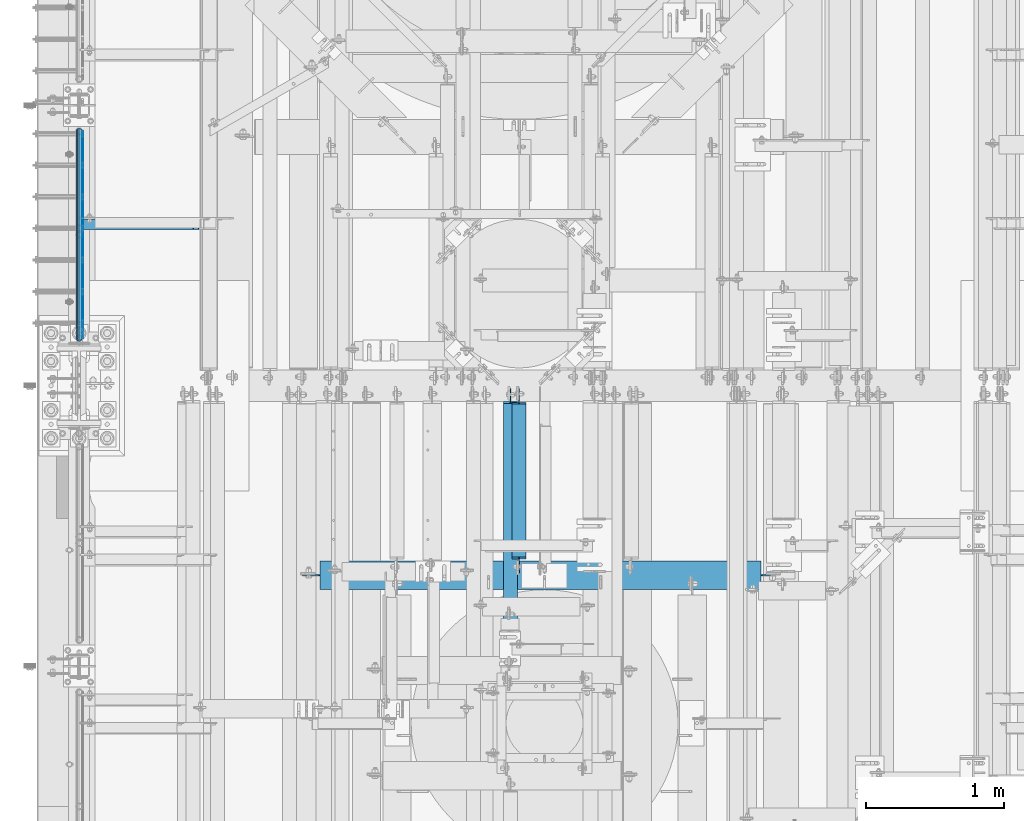
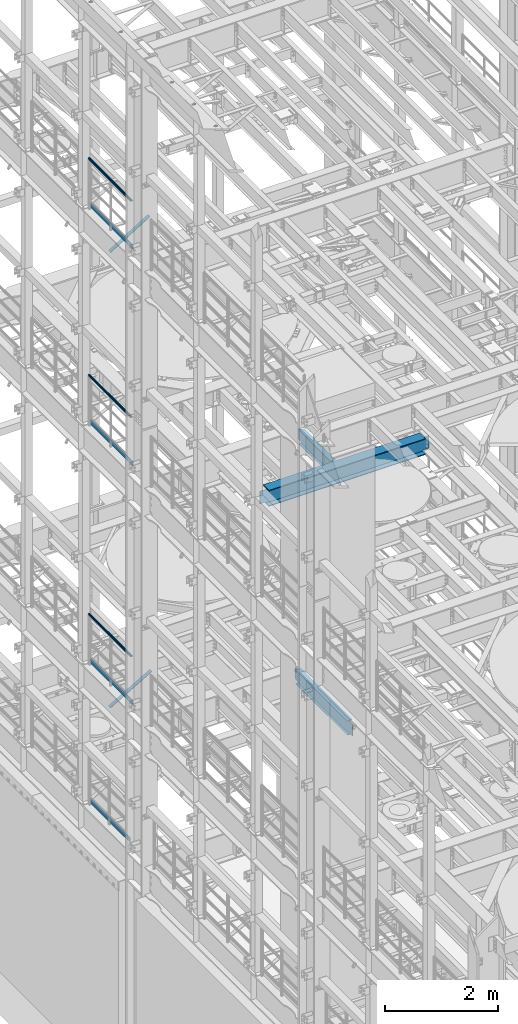
# One storey, part 1042 of 1876: 10 beams, 2 members, 9 elements without a shape of their own.
"""IFC2X3 building model written with IfcOpenShell, lengths in millimetres."""

from ifc_helpers import new_model, si_unit, frame, origin_with_axes, place, context, subcontext, project, spatial, faceted_brep, material, type_object, element, aggregate, save


model = new_model("IFC2X3")

# Units and contexts
model_context = context("Model", 3, precision=1e-05, world=origin_with_axes())
body_context = subcontext(model_context, "Body", "Model", "MODEL_VIEW")
ifc_project = project(units=[si_unit("LENGTHUNIT", "METRE", prefix="MILLI"), si_unit("AREAUNIT", "SQUARE_METRE"), si_unit("VOLUMEUNIT", "CUBIC_METRE"), si_unit("MASSUNIT", "GRAM", prefix="KILO"), si_unit("TIMEUNIT", "SECOND"), si_unit("PLANEANGLEUNIT", "RADIAN"), si_unit("SOLIDANGLEUNIT", "STERADIAN"), si_unit("THERMODYNAMICTEMPERATUREUNIT", "DEGREE_CELSIUS"), si_unit("LUMINOUSINTENSITYUNIT", "LUMEN")], contexts=[model_context])

# Site, building, storey
site_placement = place(None, origin_with_axes())
site = spatial("IfcSite", under=ifc_project, at=site_placement, CompositionType="ELEMENT")
building_placement = place(site_placement, origin_with_axes())
building = spatial("IfcBuilding", under=site, at=building_placement, Name="Undefined", CompositionType="ELEMENT")
storey_placement = place(building_placement, origin_with_axes())
storey = spatial("IfcBuildingStorey", under=building, at=storey_placement, Name="Undefined", CompositionType="ELEMENT", Elevation=0.0)

# Assembly, beam
assembly_1_placement = place(storey_placement, origin_with_axes())
assembly_1 = element("IfcElementAssembly", 1, at=assembly_1_placement, inside=storey, Name="RAIL", AssemblyPlace="NOTDEFINED", PredefinedType="RIGID_FRAME")
ifc_material_1 = material()
beam_type_1 = type_object("IfcBeamType", Name="PIPE1-1/2SCH40", PredefinedType="NOTDEFINED")
beam_1_placement = place(assembly_1_placement, frame((-1.81898940354586e-12, 7940.675, 19059.525), z_axis=(0.0, 0.0, -1.0), x_axis=(0.0, 1.0, 0.0)))
beam_1 = element("IfcBeam", 2, at=beam_1_placement, type_object=beam_type_1, material=ifc_material_1, Name="RAIL", ObjectType="PIPE1-1/2SCH40", context=body_context, shape_type="Brep", body=[
    faceted_brep([(24.1300000000001, -20.4469999999999, 0.0), (34.3535000000002, -17.7076214311803, 10.2235000000001), (1511.8715, -17.7076214311801, 10.2235000000001), (1522.095, -20.4470000000001, 0.0), (41.8376214311802, -10.2235000000001, 17.7076214311819), (1504.38737856882, -10.2235000000001, 17.7076214311819), (44.5770000000002, 0.0, 20.4470000000001), (1501.648, 0.0, 20.4470000000001), (41.8376214311802, 10.2235000000001, 17.7076214311819), (1504.38737856882, 10.2235000000001, 17.7076214311819), (34.3535000000002, 17.7076214311803, 10.2235000000001), (1511.8715, 17.7076214311801, 10.2235000000001), (24.1300000000001, 20.4469999999999, 0.0), (1522.095, 20.4470000000001, 0.0), (13.9065000000001, 17.7076214311803, -10.2235000000001), (1532.3185, 17.7076214311801, -10.2235000000001), (6.42237856882002, 10.2235000000001, -17.7076214311819), (1539.80262143118, 10.2235000000001, -17.7076214311819), (3.68299999999999, 0.0, -20.4470000000001), (1542.542, 0.0, -20.4470000000001), (6.42237856882002, -10.2235000000001, -17.7076214311819), (1539.80262143118, -10.2235000000001, -17.7076214311819), (13.9065000000001, -17.7076214311803, -10.2235000000001), (1532.3185, -17.7076214311801, -10.2235000000001), (24.1299999999854, -24.1299999999992, 0.0), (12.0650000000064, -20.8971929933177, -12.0649999999987), (1534.16, -20.8971929933186, -12.0649999999987), (1522.095, -24.1300000000001, 0.0), (3.23280700668147, -12.0650000000001, -20.8971929933177), (1542.99219299332, -12.0649999999996, -20.8971929933177), (-1.45519152283669e-11, 0.0, -24.130000000001), (1546.225, 0.0, -24.130000000001), (3.23280700668147, 12.0650000000001, -20.8971929933177), (1542.99219299332, 12.0649999999996, -20.8971929933177), (12.0650000000064, 20.8971929933177, -12.0649999999987), (1534.16, 20.8971929933186, -12.0649999999987), (24.1300000000047, 24.1299999999992, 0.0), (1522.095, 24.1300000000001, 0.0), (36.1949999999997, 20.8971929933184, 12.0649999999987), (1510.03, 20.8971929933186, 12.0649999999987), (45.0271929933187, 12.0650000000001, 20.8971929933177), (1501.19780700668, 12.0649999999996, 20.8971929933177), (48.2600000000002, 0.0, 24.130000000001), (1497.965, 0.0, 24.130000000001), (45.0271929933187, -12.0650000000001, 20.8971929933177), (1501.19780700668, -12.0649999999996, 20.8971929933177), (36.1949999999997, -20.8971929933184, 12.0649999999987), (1510.03, -20.8971929933186, 12.0649999999987)], [[[0, 1, 2, 3]], [[1, 4, 5, 2]], [[4, 6, 7, 5]], [[6, 8, 9, 7]], [[8, 10, 11, 9]], [[10, 12, 13, 11]], [[12, 14, 15, 13]], [[14, 16, 17, 15]], [[16, 18, 19, 17]], [[18, 20, 21, 19]], [[20, 22, 23, 21]], [[22, 0, 3, 23]], [[24, 25, 26, 27]], [[25, 28, 29, 26]], [[28, 30, 31, 29]], [[30, 32, 33, 31]], [[32, 34, 35, 33]], [[34, 36, 37, 35]], [[36, 38, 39, 37]], [[38, 40, 41, 39]], [[40, 42, 43, 41]], [[42, 44, 45, 43]], [[44, 46, 47, 45]], [[46, 24, 27, 47]], [[29, 31, 33, 35, 37, 39, 41, 43, 45, 47, 27, 26], [5, 7, 9, 11, 13, 15, 17, 19, 21, 23, 3, 2]], [[46, 44, 42, 40, 38, 36, 34, 32, 30, 28, 25, 24], [22, 20, 18, 16, 14, 12, 10, 8, 6, 4, 1, 0]]]),
])

assembly_2_placement = place(storey_placement, origin_with_axes())
assembly_2 = element("IfcElementAssembly", 3, at=assembly_2_placement, inside=storey, Name="RAIL", AssemblyPlace="NOTDEFINED", PredefinedType="RIGID_FRAME")
beam_2_placement = place(assembly_2_placement, frame((-1.81898940354586e-12, 7940.675, 14385.925), z_axis=(0.0, 0.0, -1.0), x_axis=(0.0, 1.0, 0.0)))
beam_2 = element("IfcBeam", 4, at=beam_2_placement, type_object=beam_type_1, material=ifc_material_1, Name="RAIL", ObjectType="PIPE1-1/2SCH40", context=body_context, shape_type="Brep", body=[
    faceted_brep([(24.1300000000001, -20.4469999999999, 0.0), (34.3535000000002, -17.7076214311803, 10.2235000000001), (1511.8715, -17.7076214311801, 10.2235000000001), (1522.095, -20.4470000000001, 0.0), (41.8376214311802, -10.2235000000001, 17.7076214311819), (1504.38737856882, -10.2235000000001, 17.7076214311819), (44.5770000000002, 0.0, 20.4470000000001), (1501.648, 0.0, 20.4470000000001), (41.8376214311802, 10.2235000000001, 17.7076214311819), (1504.38737856882, 10.2235000000001, 17.7076214311819), (34.3535000000002, 17.7076214311803, 10.2235000000001), (1511.8715, 17.7076214311801, 10.2235000000001), (24.1300000000001, 20.4469999999999, 0.0), (1522.095, 20.4470000000001, 0.0), (13.9065000000001, 17.7076214311803, -10.2235000000001), (1532.3185, 17.7076214311801, -10.2235000000001), (6.42237856882002, 10.2235000000001, -17.7076214311819), (1539.80262143118, 10.2235000000001, -17.7076214311819), (3.68299999999999, 0.0, -20.4470000000001), (1542.542, 0.0, -20.4470000000001), (6.42237856882002, -10.2235000000001, -17.7076214311819), (1539.80262143118, -10.2235000000001, -17.7076214311819), (13.9065000000001, -17.7076214311803, -10.2235000000001), (1532.3185, -17.7076214311801, -10.2235000000001), (24.1299999999854, -24.1299999999992, 0.0), (12.0650000000064, -20.8971929933177, -12.0649999999987), (1534.16, -20.8971929933186, -12.0649999999987), (1522.095, -24.1300000000001, 0.0), (3.23280700668147, -12.0650000000001, -20.8971929933177), (1542.99219299332, -12.0649999999996, -20.8971929933177), (-1.45519152283669e-11, 0.0, -24.130000000001), (1546.225, 0.0, -24.130000000001), (3.23280700668147, 12.0650000000001, -20.8971929933177), (1542.99219299332, 12.0649999999996, -20.8971929933177), (12.0650000000064, 20.8971929933177, -12.0649999999987), (1534.16, 20.8971929933186, -12.0649999999987), (24.1300000000047, 24.1299999999992, 0.0), (1522.095, 24.1300000000001, 0.0), (36.1949999999997, 20.8971929933184, 12.0649999999987), (1510.03, 20.8971929933186, 12.0649999999987), (45.0271929933187, 12.0650000000001, 20.8971929933177), (1501.19780700668, 12.0649999999996, 20.8971929933177), (48.2600000000002, 0.0, 24.130000000001), (1497.965, 0.0, 24.130000000001), (45.0271929933187, -12.0650000000001, 20.8971929933177), (1501.19780700668, -12.0649999999996, 20.8971929933177), (36.1949999999997, -20.8971929933184, 12.0649999999987), (1510.03, -20.8971929933186, 12.0649999999987)], [[[0, 1, 2, 3]], [[1, 4, 5, 2]], [[4, 6, 7, 5]], [[6, 8, 9, 7]], [[8, 10, 11, 9]], [[10, 12, 13, 11]], [[12, 14, 15, 13]], [[14, 16, 17, 15]], [[16, 18, 19, 17]], [[18, 20, 21, 19]], [[20, 22, 23, 21]], [[22, 0, 3, 23]], [[24, 25, 26, 27]], [[25, 28, 29, 26]], [[28, 30, 31, 29]], [[30, 32, 33, 31]], [[32, 34, 35, 33]], [[34, 36, 37, 35]], [[36, 38, 39, 37]], [[38, 40, 41, 39]], [[40, 42, 43, 41]], [[42, 44, 45, 43]], [[44, 46, 47, 45]], [[46, 24, 27, 47]], [[29, 31, 33, 35, 37, 39, 41, 43, 45, 47, 27, 26], [5, 7, 9, 11, 13, 15, 17, 19, 21, 23, 3, 2]], [[46, 44, 42, 40, 38, 36, 34, 32, 30, 28, 25, 24], [22, 20, 18, 16, 14, 12, 10, 8, 6, 4, 1, 0]]]),
])

assembly_3_placement = place(storey_placement, origin_with_axes())
assembly_3 = element("IfcElementAssembly", 5, at=assembly_3_placement, inside=storey, Name="RAIL", AssemblyPlace="NOTDEFINED", PredefinedType="RIGID_FRAME")
beam_3_placement = place(assembly_3_placement, frame((-1.81898940354586e-12, 7940.675, 9229.725), z_axis=(0.0, 0.0, -1.0), x_axis=(0.0, 1.0, 0.0)))
beam_3 = element("IfcBeam", 6, at=beam_3_placement, type_object=beam_type_1, material=ifc_material_1, Name="RAIL", ObjectType="PIPE1-1/2SCH40", context=body_context, shape_type="Brep", body=[
    faceted_brep([(24.1300000000001, -20.4469999999999, 0.0), (34.3535000000002, -17.7076214311803, 10.2235000000001), (1511.8715, -17.7076214311801, 10.2235000000001), (1522.095, -20.4470000000001, 0.0), (41.8376214311802, -10.2235000000001, 17.7076214311819), (1504.38737856882, -10.2235000000001, 17.7076214311819), (44.5770000000002, 0.0, 20.4470000000001), (1501.648, 0.0, 20.4470000000001), (41.8376214311802, 10.2235000000001, 17.7076214311819), (1504.38737856882, 10.2235000000001, 17.7076214311819), (34.3535000000002, 17.7076214311803, 10.2235000000001), (1511.8715, 17.7076214311801, 10.2235000000001), (24.1300000000001, 20.4469999999999, 0.0), (1522.095, 20.4470000000001, 0.0), (13.9065000000001, 17.7076214311803, -10.2235000000001), (1532.3185, 17.7076214311801, -10.2235000000001), (6.42237856882002, 10.2235000000001, -17.7076214311819), (1539.80262143118, 10.2235000000001, -17.7076214311819), (3.68299999999999, 0.0, -20.4470000000001), (1542.542, 0.0, -20.4470000000001), (6.42237856882002, -10.2235000000001, -17.7076214311819), (1539.80262143118, -10.2235000000001, -17.7076214311819), (13.9065000000001, -17.7076214311803, -10.2235000000001), (1532.3185, -17.7076214311801, -10.2235000000001), (24.1299999999854, -24.1299999999992, 0.0), (12.0650000000064, -20.8971929933177, -12.0649999999987), (1534.16, -20.8971929933186, -12.0649999999987), (1522.095, -24.1300000000001, 0.0), (3.23280700668147, -12.0650000000001, -20.8971929933177), (1542.99219299332, -12.0649999999996, -20.8971929933177), (-1.45519152283669e-11, 0.0, -24.130000000001), (1546.225, 0.0, -24.130000000001), (3.23280700668147, 12.0650000000001, -20.8971929933177), (1542.99219299332, 12.0649999999996, -20.8971929933177), (12.0650000000064, 20.8971929933177, -12.0649999999987), (1534.16, 20.8971929933186, -12.0649999999987), (24.1300000000047, 24.1299999999992, 0.0), (1522.095, 24.1300000000001, 0.0), (36.1949999999997, 20.8971929933184, 12.0649999999987), (1510.03, 20.8971929933186, 12.0649999999987), (45.0271929933187, 12.0650000000001, 20.8971929933177), (1501.19780700668, 12.0649999999996, 20.8971929933177), (48.2600000000002, 0.0, 24.130000000001), (1497.965, 0.0, 24.130000000001), (45.0271929933187, -12.0650000000001, 20.8971929933177), (1501.19780700668, -12.0649999999996, 20.8971929933177), (36.1949999999997, -20.8971929933184, 12.0649999999987), (1510.03, -20.8971929933186, 12.0649999999987)], [[[0, 1, 2, 3]], [[1, 4, 5, 2]], [[4, 6, 7, 5]], [[6, 8, 9, 7]], [[8, 10, 11, 9]], [[10, 12, 13, 11]], [[12, 14, 15, 13]], [[14, 16, 17, 15]], [[16, 18, 19, 17]], [[18, 20, 21, 19]], [[20, 22, 23, 21]], [[22, 0, 3, 23]], [[24, 25, 26, 27]], [[25, 28, 29, 26]], [[28, 30, 31, 29]], [[30, 32, 33, 31]], [[32, 34, 35, 33]], [[34, 36, 37, 35]], [[36, 38, 39, 37]], [[38, 40, 41, 39]], [[40, 42, 43, 41]], [[42, 44, 45, 43]], [[44, 46, 47, 45]], [[46, 24, 27, 47]], [[29, 31, 33, 35, 37, 39, 41, 43, 45, 47, 27, 26], [5, 7, 9, 11, 13, 15, 17, 19, 21, 23, 3, 2]], [[46, 44, 42, 40, 38, 36, 34, 32, 30, 28, 25, 24], [22, 20, 18, 16, 14, 12, 10, 8, 6, 4, 1, 0]]]),
])

# Beam
ifc_material_2 = material(Name="STEEL/A36")
beam_type_2 = type_object("IfcBeamType", PredefinedType="NOTDEFINED")
beam_4_placement = place(assembly_1_placement, frame((27.3049999999948, 7964.805, 18049.875), z_axis=(0.0, 0.0, 1.0), x_axis=(0.0, 1.0, 0.0)))
beam_4 = element("IfcBeam", 7, at=beam_4_placement, type_object=beam_type_2, material=ifc_material_2, Name="PLATE", context=body_context, shape_type="Brep", body=[
    faceted_brep([(0.0, 3.17500000000018, -50.8000000000002), (0.0, 3.17500000000018, 50.8000000000002), (1497.965, 3.175, 50.7999999999993), (1497.965, 3.175, -50.7999999999993), (0.0, -3.17500000000018, 50.8000000000002), (1497.965, -3.175, 50.7999999999993), (0.0, -3.17500000000018, -50.8000000000002), (1497.965, -3.175, -50.7999999999993)], [[[0, 1, 2, 3]], [[1, 4, 5, 2]], [[4, 6, 7, 5]], [[6, 0, 3, 7]], [[5, 7, 3, 2]], [[6, 4, 1, 0]]]),
])

aggregate(assembly_1, [beam_4, beam_1])

beam_5_placement = place(assembly_2_placement, frame((27.3049999999948, 7964.805, 13376.275), z_axis=(0.0, 0.0, 1.0), x_axis=(0.0, 1.0, 0.0)))
beam_5 = element("IfcBeam", 8, at=beam_5_placement, type_object=beam_type_2, material=ifc_material_2, Name="PLATE", context=body_context, shape_type="Brep", body=[
    faceted_brep([(0.0, 3.17500000000018, -50.8000000000002), (0.0, 3.17500000000018, 50.8000000000002), (1497.965, 3.175, 50.7999999999993), (1497.965, 3.175, -50.7999999999993), (0.0, -3.17500000000018, 50.8000000000002), (1497.965, -3.175, 50.7999999999993), (0.0, -3.17500000000018, -50.8000000000002), (1497.965, -3.175, -50.7999999999993)], [[[0, 1, 2, 3]], [[1, 4, 5, 2]], [[4, 6, 7, 5]], [[6, 0, 3, 7]], [[5, 7, 3, 2]], [[6, 4, 1, 0]]]),
])

aggregate(assembly_2, [beam_5, beam_2])

beam_6_placement = place(assembly_3_placement, frame((27.3049999999948, 7964.805, 8220.07500000001), z_axis=(0.0, 0.0, 1.0), x_axis=(0.0, 1.0, 0.0)))
beam_6 = element("IfcBeam", 9, at=beam_6_placement, type_object=beam_type_2, material=ifc_material_2, Name="PLATE", context=body_context, shape_type="Brep", body=[
    faceted_brep([(0.0, 3.17500000000018, -50.8000000000002), (0.0, 3.17500000000018, 50.8000000000002), (1497.965, 3.175, 50.7999999999993), (1497.965, 3.175, -50.7999999999993), (0.0, -3.17500000000018, 50.8000000000002), (1497.965, -3.175, 50.7999999999993), (0.0, -3.17500000000018, -50.8000000000002), (1497.965, -3.175, -50.7999999999993)], [[[0, 1, 2, 3]], [[1, 4, 5, 2]], [[4, 6, 7, 5]], [[6, 0, 3, 7]], [[5, 7, 3, 2]], [[6, 4, 1, 0]]]),
])

aggregate(assembly_3, [beam_6, beam_3])

# Assembly, beam
assembly_4_placement = place(storey_placement, origin_with_axes())
assembly_4 = element("IfcElementAssembly", 10, at=assembly_4_placement, inside=storey, Name="RAIL", AssemblyPlace="NOTDEFINED", PredefinedType="RIGID_FRAME")
beam_7_placement = place(assembly_4_placement, frame((27.3049999999948, 8060.055, 5197.475), z_axis=(0.0, 0.0, 1.0), x_axis=(0.0, 1.0, 0.0)))
beam_7 = element("IfcBeam", 11, at=beam_7_placement, type_object=beam_type_2, material=ifc_material_2, Name="PLATE", context=body_context, shape_type="Brep", body=[
    faceted_brep([(0.0, 3.17500000000018, -50.8000000000002), (0.0, 3.17500000000018, 50.8000000000002), (1402.715, 3.175, 50.8000000000002), (1402.715, 3.175, -50.8000000000002), (0.0, -3.17500000000018, 50.8000000000002), (1402.715, -3.175, 50.8000000000002), (0.0, -3.17500000000018, -50.8000000000002), (1402.715, -3.175, -50.8000000000002)], [[[0, 1, 2, 3]], [[1, 4, 5, 2]], [[4, 6, 7, 5]], [[6, 0, 3, 7]], [[5, 7, 3, 2]], [[6, 4, 1, 0]]]),
])
aggregate(assembly_4, [beam_7])

# Assembly, member
assembly_5_placement = place(storey_placement, origin_with_axes())
assembly_5 = element("IfcElementAssembly", 12, at=assembly_5_placement, inside=storey, AssemblyPlace="NOTDEFINED", PredefinedType="RIGID_FRAME")
member_type = type_object("IfcMemberType", Name="L3X3X3/8", PredefinedType="NOTDEFINED")
member_1_placement = place(assembly_5_placement, frame((19.0458151523234, 8791.575, 7599.70204228665), z_axis=(0.0, -1.0, 0.0), x_axis=(0.866088809372667, 0.0, 0.499890162215098)))
member_1 = element("IfcMember", 13, at=member_1_placement, type_object=member_type, material=ifc_material_2, ObjectType="L3X3X3/8", context=body_context, shape_type="Brep", body=[
    faceted_brep([(997.169004128596, -38.0999999996484, -28.5750000000007), (997.169004128596, -38.0999999996484, -38.1000000000004), (997.169004128632, 38.1000000003687, -38.1000000000004), (997.169004128632, 38.1000000003687, 38.1000000000004), (997.169004128628, 28.5750000003663, 38.1000000000004), (997.169004128628, 28.5750000003663, -28.5750000000007), (22.911911287435, 28.5750000000162, 38.1000000000004), (22.911911287435, 28.5750000000162, -28.5750000000007), (22.9119112874018, -38.0999999999995, -28.5750000000007), (22.9119112874018, -38.0999999999995, -38.1000000000004), (22.9119112874396, 38.1000000000186, -38.1000000000004), (22.9119112874396, 38.1000000000186, 38.1000000000004)], [[[0, 1, 2, 3, 4, 5]], [[5, 4, 6, 7]], [[0, 5, 7, 8]], [[1, 0, 8, 9]], [[2, 1, 9, 10]], [[3, 2, 10, 11]], [[4, 3, 11, 6]], [[10, 9, 8, 7, 6, 11]]]),
])
aggregate(assembly_5, [member_1])

assembly_6_placement = place(storey_placement, origin_with_axes())
assembly_6 = element("IfcElementAssembly", 14, at=assembly_6_placement, inside=storey, AssemblyPlace="NOTDEFINED", PredefinedType="RIGID_FRAME")
member_2_placement = place(assembly_6_placement, frame((19.9928945830509, 8791.575, 17420.4891604457), z_axis=(0.0, -1.0, 0.0), x_axis=(0.851257688514323, 0.0, 0.524747889700618)))
member_2 = element("IfcMember", 15, at=member_2_placement, type_object=member_type, material=ifc_material_2, ObjectType="L3X3X3/8", context=body_context, shape_type="Brep", body=[
    faceted_brep([(25.5909295921792, 38.1000000000076, -38.1000000000004), (25.5909295921938, -38.1000000000404, -38.1000000000004), (25.5909295921938, -38.1000000000404, -28.5750000000007), (25.5909295921811, 28.5750000000025, -28.5750000000007), (25.5909295921811, 28.5750000000025, 38.1000000000004), (25.5909295921792, 38.1000000000076, 38.1000000000004), (968.184782924762, 28.5749999994605, 38.1000000000004), (968.18478292476, 38.0999999994638, 38.1000000000004), (968.18478292476, 38.0999999994638, -38.1000000000004), (968.184782924776, -38.1000000005788, -38.1000000000004), (968.184782924776, -38.1000000005788, -28.5750000000007), (968.184782924762, 28.5749999994605, -28.5750000000007)], [[[0, 1, 2, 3, 4, 5]], [[5, 4, 6, 7]], [[0, 5, 7, 8]], [[1, 0, 8, 9]], [[2, 1, 9, 10]], [[3, 2, 10, 11]], [[4, 3, 11, 6]], [[10, 9, 8, 7, 6, 11]]]),
])
aggregate(assembly_6, [member_2])

# Assembly, beam
assembly_7_placement = place(storey_placement, origin_with_axes())
assembly_7 = element("IfcElementAssembly", 16, at=assembly_7_placement, inside=storey, Name="BEAM", AssemblyPlace="NOTDEFINED", PredefinedType="RIGID_FRAME")
ifc_material_3 = material(Name="STEEL/A992")
beam_type_3 = type_object("IfcBeamType", Name="W12X16", PredefinedType="NOTDEFINED")
beam_8_placement = place(assembly_7_placement, frame((3187.7, 6115.05, 13157.2), z_axis=(0.0, 0.0, 1.0), x_axis=(0.0, 1.0, 0.0)))
beam_8 = element("IfcBeam", 17, at=beam_8_placement, type_object=beam_type_3, material=ifc_material_3, Name="BEAM", ObjectType="W12X16", context=body_context, shape_type="Brep", body=[
    faceted_brep([(148.431250000001, -3.17500000000018, -127.0), (148.431250000001, 3.17500000000018, -127.0), (237.331250190735, 3.17500000000018, -127.0), (237.331250190735, -3.17500000000018, -127.0), (242.19132970878, 3.17500000000018, -127.966729922588), (242.19132970878, -3.17500000000018, -127.966729922588), (246.311506176934, 3.17500000000018, -130.719743823067), (246.311506176934, -3.17500000000018, -130.719743823067), (249.064520077412, 3.17500000000018, -134.839920291221), (249.064520077412, -3.17500000000018, -134.839920291221), (250.03125, -3.17500000000018, -139.699999809265), (250.03125, 3.17500000000018, -139.699999809265), (250.031249999999, 3.17500000000018, -146.049999999999), (250.031249999999, 50.8000000000002, -146.049999999999), (250.031249999999, 50.8000000000002, -152.4), (250.031249999999, -50.8000000000002, -152.4), (250.031249999999, -50.8000000000002, -146.049999999999), (250.031249999999, -3.17500000000018, -146.049999999999), (1370.80625, 50.8000000000002, 146.049999999999), (1370.80625, 3.17500000000018, 146.049999999999), (262.73125, 3.17500000000018, 146.049999999999), (262.73125, 50.8000000000002, 146.049999999999), (250.031250190735, -3.17500000000018, 107.950000000001), (250.031250190735, 3.17500000000018, 107.950000000001), (148.431250000001, 3.17500000000018, 107.950000000001), (148.431250000001, -3.17500000000018, 107.950000000001), (254.89132970878, -3.17500000000018, 108.916729922588), (254.89132970878, 3.17500000000018, 108.916729922588), (259.011506176934, -3.17500000000018, 111.669743823066), (259.011506176934, 3.17500000000018, 111.669743823066), (261.764520077412, -3.17500000000018, 115.789920291219), (261.764520077412, 3.17500000000018, 115.789920291219), (262.73125, -3.17500000000018, 120.649999809266), (262.73125, 3.17500000000018, 120.649999809266), (1370.80625, -50.8000000000002, 152.4), (1370.80625, 50.8000000000002, 152.4), (262.73125, 50.8000000000002, 152.4), (262.73125, -50.8000000000002, 152.4), (1370.80625, -50.8000000000002, 146.049999999999), (262.73125, -50.8000000000002, 146.049999999999), (1370.80625, -3.17500000000018, 146.049999999999), (262.73125, -3.17500000000018, 146.049999999999), (1370.80625, -3.17500000000018, 126.999999809264), (1370.80625, 3.17500000000018, 126.999999809264), (1371.77297992259, -3.17500000000018, 122.139920291218), (1371.77297992259, 3.17500000000018, 122.139920291218), (1374.52599382306, -3.17500000000018, 118.019743823064), (1374.52599382306, 3.17500000000018, 118.019743823064), (1378.64617029122, -3.17500000000018, 115.266729922587), (1378.64617029122, 3.17500000000018, 115.266729922587), (1383.50624980926, -3.17500000000018, 114.299999999999), (1383.50624980926, 3.17500000000018, 114.299999999999), (1485.10625, -3.17500000000018, 114.299999999999), (1485.10625, 3.17500000000018, 114.299999999999), (1485.10625, -3.17500000000018, -127.0), (1485.10625, 3.17500000000018, -127.0), (1396.20624980926, -3.17500000000018, -127.0), (1396.20624980926, 3.17500000000018, -127.0), (1391.34617029122, -3.17500000000018, -127.966729922588), (1391.34617029122, 3.17500000000018, -127.966729922588), (1387.22599382306, -3.17500000000018, -130.719743823065), (1387.22599382306, 3.17500000000018, -130.719743823065), (1384.47297992259, -3.17500000000018, -134.839920291219), (1384.47297992259, 3.17500000000018, -134.839920291219), (1383.50625, -3.17500000000018, -139.699999809265), (1383.50625, 3.17500000000018, -139.699999809265), (1383.50625, -3.17500000000018, -146.049999999999), (1383.50625, -50.8000000000002, -146.049999999999), (1383.50625, -50.8000000000002, -152.4), (1383.50625, 50.8000000000002, -152.4), (1383.50625, 50.8000000000002, -146.049999999999), (1383.50625, 3.17500000000018, -146.049999999999)], [[[0, 1, 2, 3]], [[3, 2, 4, 5]], [[5, 4, 6, 7]], [[7, 6, 8, 9]], [[10, 11, 12, 13, 14, 15, 16, 17]], [[9, 8, 11, 10]], [[18, 19, 20, 21]], [[22, 23, 24, 25]], [[26, 27, 23, 22]], [[28, 29, 27, 26]], [[30, 31, 29, 28]], [[32, 33, 31, 30]], [[34, 35, 36, 37]], [[38, 34, 37, 39]], [[40, 38, 39, 41]], [[37, 36, 21, 20, 33, 32, 41, 39]], [[35, 18, 21, 36]], [[34, 38, 40, 42, 43, 19, 18, 35]], [[44, 45, 43, 42]], [[46, 47, 45, 44]], [[48, 49, 47, 46]], [[50, 51, 49, 48]], [[52, 53, 51, 50]], [[53, 52, 54, 55]], [[54, 56, 57, 55]], [[58, 59, 57, 56]], [[60, 61, 59, 58]], [[62, 63, 61, 60]], [[64, 65, 63, 62]], [[66, 67, 68, 69, 70, 71, 65, 64]], [[67, 66, 17, 16]], [[68, 67, 16, 15]], [[69, 68, 15, 14]], [[70, 69, 14, 13]], [[71, 70, 13, 12]], [[6, 4, 2, 1, 24, 23, 27, 29, 31, 33, 20, 19, 43, 45, 47, 49, 51, 53, 55, 57, 59, 61, 63, 65, 71, 12, 11, 8]], [[25, 24, 1, 0]], [[66, 64, 62, 60, 58, 56, 54, 52, 50, 48, 46, 44, 42, 40, 41, 32, 30, 28, 26, 22, 25, 0, 3, 5, 7, 9, 10, 17]]]),
])
aggregate(assembly_7, [beam_8])

assembly_8_placement = place(storey_placement, origin_with_axes())
assembly_8 = element("IfcElementAssembly", 18, at=assembly_8_placement, inside=storey, Name="BEAM", AssemblyPlace="NOTDEFINED", PredefinedType="RIGID_FRAME")
beam_9_placement = place(assembly_8_placement, frame((3124.2, 5556.25, 8001.0), z_axis=(0.0, 0.0, 1.0), x_axis=(0.0, 1.0, 0.0)))
beam_9 = element("IfcBeam", 19, at=beam_9_placement, type_object=beam_type_3, material=ifc_material_3, Name="BEAM", ObjectType="W12X16", context=body_context, shape_type="Brep", body=[
    faceted_brep([(1948.65625, -3.17500000000018, -146.049999999999), (1948.65625, -50.8000000000002, -146.049999999999), (1948.65625, -50.8000000000002, -152.4), (1948.65625, 50.8000000000002, -152.4), (1948.65625, 50.8000000000002, -146.049999999999), (1948.65625, 3.17500000000018, -146.049999999999), (1948.65625, 3.17500000000018, -139.699999809266), (1948.65625, -3.17500000000018, -139.699999809266), (1949.62297992259, 3.17500000000018, -134.839920291221), (1949.62297992259, -3.17500000000018, -134.839920291221), (1952.37599382306, 3.17500000000018, -130.719743823067), (1952.37599382306, -3.17500000000018, -130.719743823067), (1956.49617029122, 3.17500000000018, -127.966729922588), (1956.49617029122, -3.17500000000018, -127.966729922588), (1961.35625, 3.17500000000018, -126.999999999996), (1961.35625, -3.17500000000018, -126.999999999996), (2043.90625, -3.17500000000018, -127.000000000001), (2043.90625, 3.17500000000018, -127.000000000001), (118.268749999994, 3.17500000000018, 146.05), (118.268749999994, 50.8000000000002, 146.05), (1935.95625, 50.8000000000002, 146.05), (1935.95625, 3.17500000000018, 146.05), (111.918749999993, -3.17500000000018, -139.699999809265), (111.918749999993, 3.17500000000018, -139.699999809265), (111.918749999993, 3.17500000000018, -146.05), (111.918749999993, 50.8000000000002, -146.05), (111.918749999993, 50.8000000000002, -152.4), (111.918749999993, -50.8000000000002, -152.4), (111.918749999993, -50.8000000000002, -146.05), (111.918749999993, -3.17500000000018, -146.05), (110.952020077406, -3.17500000000018, -134.83992029122), (110.952020077406, 3.17500000000018, -134.83992029122), (108.199006176927, -3.17500000000018, -130.719743823066), (108.199006176927, 3.17500000000018, -130.719743823066), (104.078829708774, -3.17500000000018, -127.966729922588), (104.078829708774, 3.17500000000018, -127.966729922588), (99.2187500000005, -3.17500000000018, -127.0), (99.2187500000005, 3.17500000000018, -127.0), (16.6687499999944, -3.17500000000018, -127.0), (16.6687499999944, 3.17500000000018, -127.0), (16.6687499999944, -3.17500000000018, 127.0), (16.6687499999944, 3.17500000000018, 127.0), (105.568750190729, -3.17500000000018, 127.0), (105.568750190729, 3.17500000000018, 127.0), (110.428829708774, -3.17500000000018, 127.966729922588), (110.428829708774, 3.17500000000018, 127.966729922588), (114.549006176928, -3.17500000000018, 130.719743823066), (114.549006176928, 3.17500000000018, 130.719743823066), (117.302020077406, -3.17500000000018, 134.83992029122), (117.302020077406, 3.17500000000018, 134.83992029122), (118.268749999994, -3.17500000000018, 139.699999809265), (118.268749999994, 3.17500000000018, 139.699999809265), (118.268749999994, -50.8000000000002, 152.4), (118.268749999994, 50.8000000000002, 152.4), (118.268749999994, -3.17500000000018, 146.05), (118.268749999994, -50.8000000000002, 146.05), (1935.95625, -3.17500000000018, 146.05), (1935.95625, -50.8000000000002, 146.05), (1935.95625, -50.8000000000002, 152.4), (1935.95625, 50.8000000000002, 152.4), (1935.95625, -3.17500000000018, 126.999999809264), (1935.95625, 3.17500000000018, 126.999999809264), (1936.92297992259, -3.17500000000018, 122.139920291219), (1936.92297992259, 3.17500000000018, 122.139920291219), (1939.67599382306, -3.17500000000018, 118.019743823065), (1939.67599382306, 3.17500000000018, 118.019743823065), (1943.79617029122, -3.17500000000018, 115.266729922587), (1943.79617029122, 3.17500000000018, 115.266729922587), (1948.65625, -3.17500000000018, 114.299999999999), (1948.65625, 3.17500000000018, 114.299999999999), (2043.90625, -3.17500000000018, 114.299999999999), (2043.90625, 3.17500000000018, 114.299999999999)], [[[0, 1, 2, 3, 4, 5, 6, 7]], [[7, 6, 8, 9]], [[9, 8, 10, 11]], [[11, 10, 12, 13]], [[13, 12, 14, 15]], [[16, 15, 14, 17]], [[18, 19, 20, 21]], [[22, 23, 24, 25, 26, 27, 28, 29]], [[30, 31, 23, 22]], [[32, 33, 31, 30]], [[34, 35, 33, 32]], [[36, 37, 35, 34]], [[38, 39, 37, 36]], [[40, 41, 39, 38]], [[42, 43, 41, 40]], [[44, 45, 43, 42]], [[46, 47, 45, 44]], [[48, 49, 47, 46]], [[50, 51, 49, 48]], [[52, 53, 19, 18, 51, 50, 54, 55]], [[55, 54, 56, 57]], [[52, 55, 57, 58]], [[53, 52, 58, 59]], [[19, 53, 59, 20]], [[58, 57, 56, 60, 61, 21, 20, 59]], [[62, 63, 61, 60]], [[64, 65, 63, 62]], [[66, 67, 65, 64]], [[68, 69, 67, 66]], [[70, 71, 69, 68]], [[71, 70, 16, 17]], [[12, 10, 8, 6, 5, 24, 23, 31, 33, 35, 37, 39, 41, 43, 45, 47, 49, 51, 18, 21, 61, 63, 65, 67, 69, 71, 17, 14]], [[25, 24, 5, 4]], [[26, 25, 4, 3]], [[27, 26, 3, 2]], [[28, 27, 2, 1]], [[29, 28, 1, 0]], [[70, 68, 66, 64, 62, 60, 56, 54, 50, 48, 46, 44, 42, 40, 38, 36, 34, 32, 30, 22, 29, 0, 7, 9, 11, 13, 15, 16]]]),
])
aggregate(assembly_8, [beam_9])

assembly_9_placement = place(storey_placement, origin_with_axes())
assembly_9 = element("IfcElementAssembly", 20, at=assembly_9_placement, inside=storey, Name="BEAM", AssemblyPlace="NOTDEFINED", PredefinedType="RIGID_FRAME")
beam_type_4 = type_object("IfcBeamType", Name="W14X48", PredefinedType="NOTDEFINED")
beam_10_placement = place(assembly_9_placement, frame((1625.6, 6246.8125, 13134.975), z_axis=(0.0, 0.0, 1.0), x_axis=(1.0, 0.0, 0.0)))
beam_10 = element("IfcBeam", 21, at=beam_10_placement, type_object=beam_type_4, material=ifc_material_3, Name="BEAM", ObjectType="W14X48", context=body_context, shape_type="Brep", body=[
    faceted_brep([(3315.49375, -3.96875, -158.75), (3315.49375, -101.6, -158.75), (3315.49375, -101.6, -174.625), (3315.49375, 101.6, -174.625), (3315.49375, 101.6, -158.75), (3315.49375, 3.96875, -158.75), (3315.49375, 3.96875, -149.224999809267), (3315.49375, -3.96875, -149.224999809267), (3316.46047992259, 3.96875, -144.36492029122), (3316.46047992259, -3.96875, -144.36492029122), (3319.21349382307, 3.96875, -140.244743823067), (3319.21349382307, -3.96875, -140.244743823067), (3323.33367029122, 3.96875, -137.491729922589), (3323.33367029122, -3.96875, -137.491729922589), (3328.19374980927, 3.96875, -136.525000000001), (3328.19374980927, -3.96875, -136.525000000001), (3442.49375, -3.96875, -136.525000000001), (3442.49375, 3.96875, -136.525000000001), (119.85625, 3.96875, 158.75), (119.85625, 101.6, 158.75), (3315.49375, 101.6, 158.75), (3315.49375, 3.96875, 158.75), (119.856250000001, -3.96875, -149.224999809267), (119.856250000001, 3.96875, -149.224999809267), (119.85625, 3.96875, -158.75), (119.85625, 101.6, -158.75), (119.85625, 101.6, -174.625), (119.85625, -101.6, -174.625), (119.85625, -101.6, -158.75), (119.85625, -3.96875, -158.75), (118.889520077413, -3.96875, -144.36492029122), (118.889520077413, 3.96875, -144.36492029122), (116.136506176935, -3.96875, -140.244743823067), (116.136506176935, 3.96875, -140.244743823067), (112.016329708781, -3.96875, -137.491729922589), (112.016329708781, 3.96875, -137.491729922589), (107.156250190735, -3.96875, -136.525000000001), (107.156250190735, 3.96875, -136.525000000001), (-7.1437499999995, -3.96875, -136.525000000001), (-7.1437499999995, 3.96875, -136.525000000001), (-7.1437499999995, -3.96875, 136.524999999998), (-7.1437499999995, 3.96875, 136.524999999998), (107.156250190735, -3.96875, 136.524999999998), (107.156250190735, 3.96875, 136.524999999998), (112.016329708781, -3.96875, 137.491729922585), (112.016329708781, 3.96875, 137.491729922585), (116.136506176935, -3.96875, 140.244743823063), (116.136506176935, 3.96875, 140.244743823063), (118.889520077413, -3.96875, 144.364920291217), (118.889520077413, 3.96875, 144.364920291217), (119.856250000001, -3.96875, 149.224999809263), (119.856250000001, 3.96875, 149.224999809263), (119.85625, -101.6, 174.625), (119.85625, 101.6, 174.625), (119.85625, -3.96875, 158.75), (119.85625, -101.6, 158.75), (3315.49375, -3.96875, 158.75), (3315.49375, -101.6, 158.75), (3315.49375, -101.6, 174.625), (3315.49375, 101.6, 174.625), (3315.49375, -3.96875, 149.224999809263), (3315.49375, 3.96875, 149.224999809263), (3316.46047992259, -3.96875, 144.364920291217), (3316.46047992259, 3.96875, 144.364920291217), (3319.21349382307, -3.96875, 140.244743823063), (3319.21349382307, 3.96875, 140.244743823063), (3323.33367029122, -3.96875, 137.491729922585), (3323.33367029122, 3.96875, 137.491729922585), (3328.19374980927, -3.96875, 136.524999999998), (3328.19374980927, 3.96875, 136.524999999998), (3442.49375, -3.96875, 136.524999999998), (3442.49375, 3.96875, 136.524999999998)], [[[0, 1, 2, 3, 4, 5, 6, 7]], [[7, 6, 8, 9]], [[9, 8, 10, 11]], [[11, 10, 12, 13]], [[13, 12, 14, 15]], [[16, 15, 14, 17]], [[18, 19, 20, 21]], [[22, 23, 24, 25, 26, 27, 28, 29]], [[30, 31, 23, 22]], [[32, 33, 31, 30]], [[34, 35, 33, 32]], [[36, 37, 35, 34]], [[38, 39, 37, 36]], [[40, 41, 39, 38]], [[42, 43, 41, 40]], [[44, 45, 43, 42]], [[46, 47, 45, 44]], [[48, 49, 47, 46]], [[50, 51, 49, 48]], [[52, 53, 19, 18, 51, 50, 54, 55]], [[55, 54, 56, 57]], [[52, 55, 57, 58]], [[53, 52, 58, 59]], [[19, 53, 59, 20]], [[58, 57, 56, 60, 61, 21, 20, 59]], [[62, 63, 61, 60]], [[64, 65, 63, 62]], [[66, 67, 65, 64]], [[68, 69, 67, 66]], [[70, 71, 69, 68]], [[71, 70, 16, 17]], [[12, 10, 8, 6, 5, 24, 23, 31, 33, 35, 37, 39, 41, 43, 45, 47, 49, 51, 18, 21, 61, 63, 65, 67, 69, 71, 17, 14]], [[25, 24, 5, 4]], [[26, 25, 4, 3]], [[27, 26, 3, 2]], [[28, 27, 2, 1]], [[29, 28, 1, 0]], [[70, 68, 66, 64, 62, 60, 56, 54, 50, 48, 46, 44, 42, 40, 38, 36, 34, 32, 30, 22, 29, 0, 7, 9, 11, 13, 15, 16]]]),
])
aggregate(assembly_9, [beam_10])

save(model, "model.ifc")
